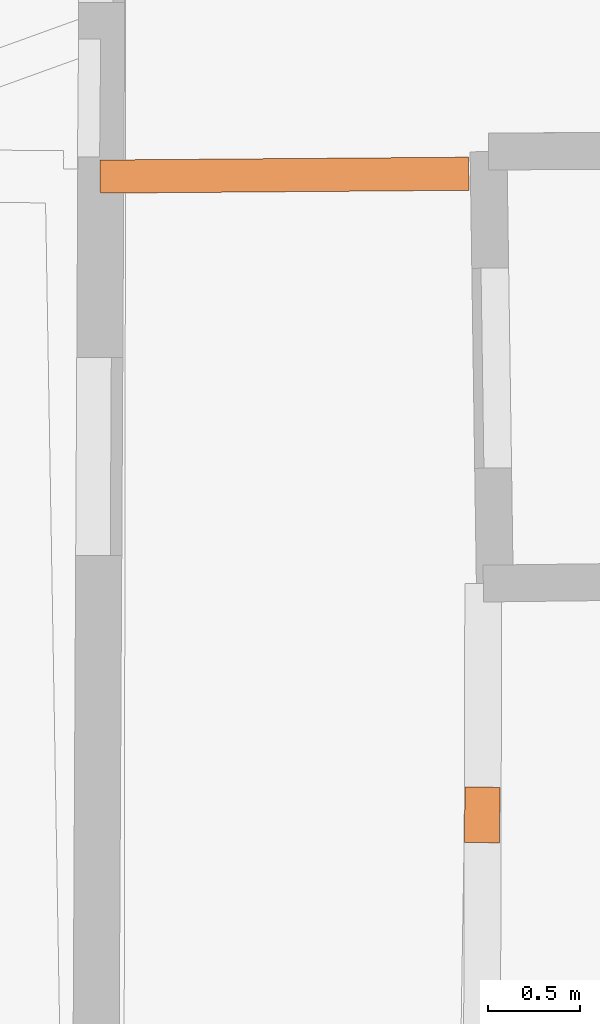
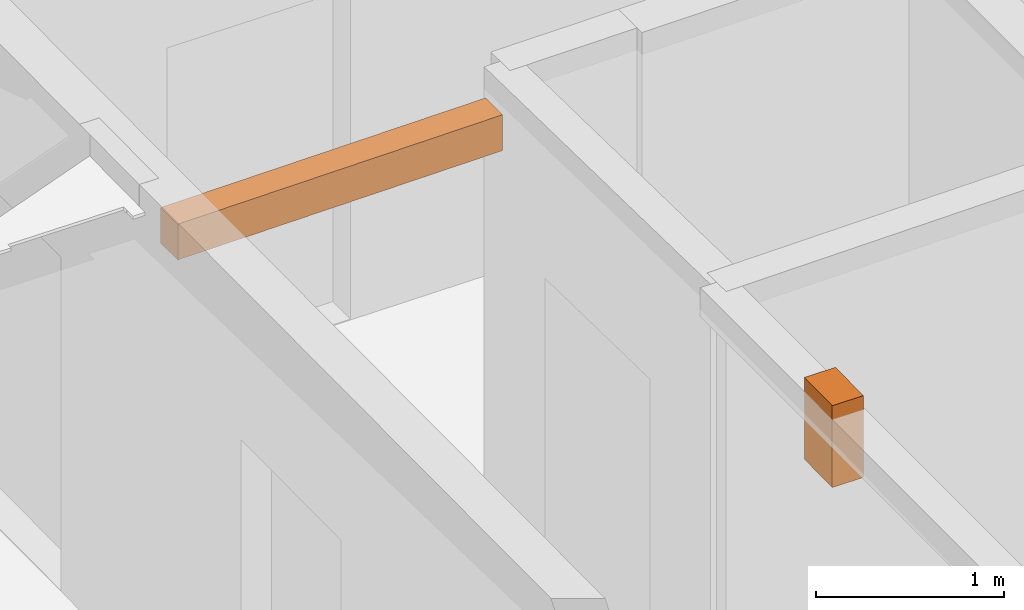
# One storey, part 14 of 14: 2 proxies.
"""IFC2X3 building model written with IfcOpenShell, lengths in metres."""

from ifc_helpers import new_model, entity, si_unit, converted_unit, derived_unit, direction, frame, origin, place, context, subcontext, project, spatial, polyline, outline, extrude, source, transform, mapped, material, type_object, type_shapes, element, save


model = new_model("IFC2X3")

# Units and contexts
model_context = context("Model", 3, precision=1e-05, world=origin(), true_north=direction((0.0, 1.0)))
body_context = subcontext(model_context, "Body", "Model", "MODEL_VIEW")
ifc_project = project(units=[si_unit("LENGTHUNIT", "METRE"), si_unit("AREAUNIT", "SQUARE_METRE"), si_unit("VOLUMEUNIT", "CUBIC_METRE"), converted_unit("PLANEANGLEUNIT", "DEGREE", entity("IfcRatioMeasure", 0.0174532925199433), si_unit("PLANEANGLEUNIT", "RADIAN"), dimensions=[0, 0, 0, 0, 0, 0, 0]), si_unit("MASSUNIT", "GRAM", prefix="KILO"), derived_unit("MASSDENSITYUNIT", [(si_unit("MASSUNIT", "GRAM", prefix="KILO"), 1), (si_unit("LENGTHUNIT", "METRE"), -3)]), derived_unit("MOMENTOFINERTIAUNIT", [(si_unit("LENGTHUNIT", "METRE"), 4)]), si_unit("TIMEUNIT", "SECOND"), si_unit("FREQUENCYUNIT", "HERTZ"), si_unit("THERMODYNAMICTEMPERATUREUNIT", "DEGREE_CELSIUS"), derived_unit("THERMALTRANSMITTANCEUNIT", [(si_unit("MASSUNIT", "GRAM", prefix="KILO"), 1), (si_unit("THERMODYNAMICTEMPERATUREUNIT", "KELVIN"), -1), (si_unit("TIMEUNIT", "SECOND"), -3)]), derived_unit("VOLUMETRICFLOWRATEUNIT", [(si_unit("LENGTHUNIT", "METRE"), 3), (si_unit("TIMEUNIT", "SECOND"), -1)]), si_unit("ELECTRICCURRENTUNIT", "AMPERE"), si_unit("ELECTRICVOLTAGEUNIT", "VOLT"), si_unit("POWERUNIT", "WATT"), si_unit("FORCEUNIT", "NEWTON", prefix="KILO"), si_unit("ILLUMINANCEUNIT", "LUX"), si_unit("LUMINOUSFLUXUNIT", "LUMEN"), si_unit("LUMINOUSINTENSITYUNIT", "CANDELA"), derived_unit("USERDEFINED", [(si_unit("MASSUNIT", "GRAM", prefix="KILO"), -1), (si_unit("LENGTHUNIT", "METRE"), -2), (si_unit("TIMEUNIT", "SECOND"), 3), (si_unit("LUMINOUSFLUXUNIT", "LUMEN"), 1)]), derived_unit("LINEARVELOCITYUNIT", [(si_unit("LENGTHUNIT", "METRE"), 1), (si_unit("TIMEUNIT", "SECOND"), -1)]), si_unit("PRESSUREUNIT", "PASCAL"), derived_unit("USERDEFINED", [(si_unit("LENGTHUNIT", "METRE"), -2), (si_unit("MASSUNIT", "GRAM", prefix="KILO"), 1), (si_unit("TIMEUNIT", "SECOND"), -2)]), derived_unit("LINEARFORCEUNIT", [(si_unit("MASSUNIT", "GRAM", prefix="KILO"), 1), (si_unit("LENGTHUNIT", "METRE"), 1), (si_unit("TIMEUNIT", "SECOND"), -2), (si_unit("LENGTHUNIT", "METRE"), -1)]), derived_unit("PLANARFORCEUNIT", [(si_unit("MASSUNIT", "GRAM", prefix="KILO"), 1), (si_unit("LENGTHUNIT", "METRE"), 1), (si_unit("TIMEUNIT", "SECOND"), -2), (si_unit("LENGTHUNIT", "METRE"), -2)])], contexts=[model_context])

# Site, building, storey
placement_1 = place(None, origin())
site = spatial("IfcSite", under=ifc_project, at=placement_1, CompositionType="ELEMENT")
building = spatial("IfcBuilding", under=site, at=placement_1, CompositionType="ELEMENT")
storey_placement = place(placement_1, frame((0.0, 0.0, 8.83152770996094)))
storey = spatial("IfcBuildingStorey", under=building, at=storey_placement, Name="Level 4", CompositionType="ELEMENT", Elevation=8.83152770996094)

# Proxies
ifc_material = material(Name="Beam default")
building_element_proxy_type_1 = type_object("IfcBuildingElementProxyType", Name="Beam:196", PredefinedType="NOTDEFINED")
shared_shape_1 = source(origin(), body_context, "Body", "SweptSolid", [
    extrude(outline(polyline([(1.99999997113264, -0.0900000035762787), (1.99999997113264, 0.0900000035762787), (0.0, 0.0900000035762787), (0.0, -0.0900000035762787), (1.99999997113264, -0.0900000035762787)])), origin(), (0.0, 0.0, 1.0), 0.231999397277832),
])
type_shapes(building_element_proxy_type_1, [shared_shape_1])
placement_2 = place(placement_1, frame((0.0, 0.0, 11.5650005340576)))
proxy_1_placement = place(placement_2, frame((2.96319901596308, 57.6699438410779, 0.0), z_axis=(0.0, 0.0, 1.0), x_axis=(0.999969496855116, 0.00781059276410279, 0.0)))
element("IfcBuildingElementProxy", 1, at=proxy_1_placement, inside=storey, type_object=building_element_proxy_type_1, material=ifc_material, Name="Beam:196", ObjectType="Beam", context=body_context, shape_type="MappedRepresentation", body=[
    mapped(shared_shape_1, transform((0.0, 0.0, 0.0), scale=1.0)),
])
building_element_proxy_type_2 = type_object("IfcBuildingElementProxyType", Name="Beam:772", PredefinedType="NOTDEFINED")
shared_shape_2 = source(origin(), body_context, "Body", "SweptSolid", [
    extrude(outline(polyline([(0.301340831707218, -0.0949999988079071), (0.301340831707218, 0.0949999988079071), (0.0, 0.0949999988079071), (0.0, -0.0949999988079071), (0.301340831707218, -0.0949999988079071)])), origin(), (0.0, 0.0, 1.0), 0.529999732971191),
])
type_shapes(building_element_proxy_type_2, [shared_shape_2])
placement_3 = place(placement_1, frame((0.0, 0.0, 11.53600025177)))
proxy_2_placement = place(placement_3, frame((5.03771489719268, 54.3573751351887, 0.0), z_axis=(0.0, 0.0, 1.0), x_axis=(-0.00966678887477536, -0.999953275504836, 0.0)))
element("IfcBuildingElementProxy", 2, at=proxy_2_placement, inside=storey, type_object=building_element_proxy_type_2, material=ifc_material, Name="Beam:772", ObjectType="Beam", context=body_context, shape_type="MappedRepresentation", body=[
    mapped(shared_shape_2, transform((0.0, 0.0, 0.0), scale=1.0)),
])

save(model, "model.ifc")
